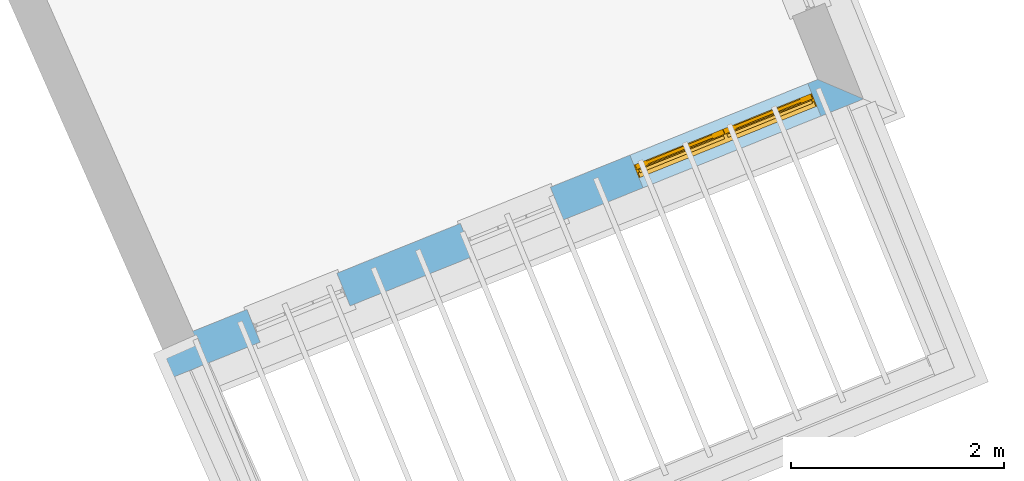
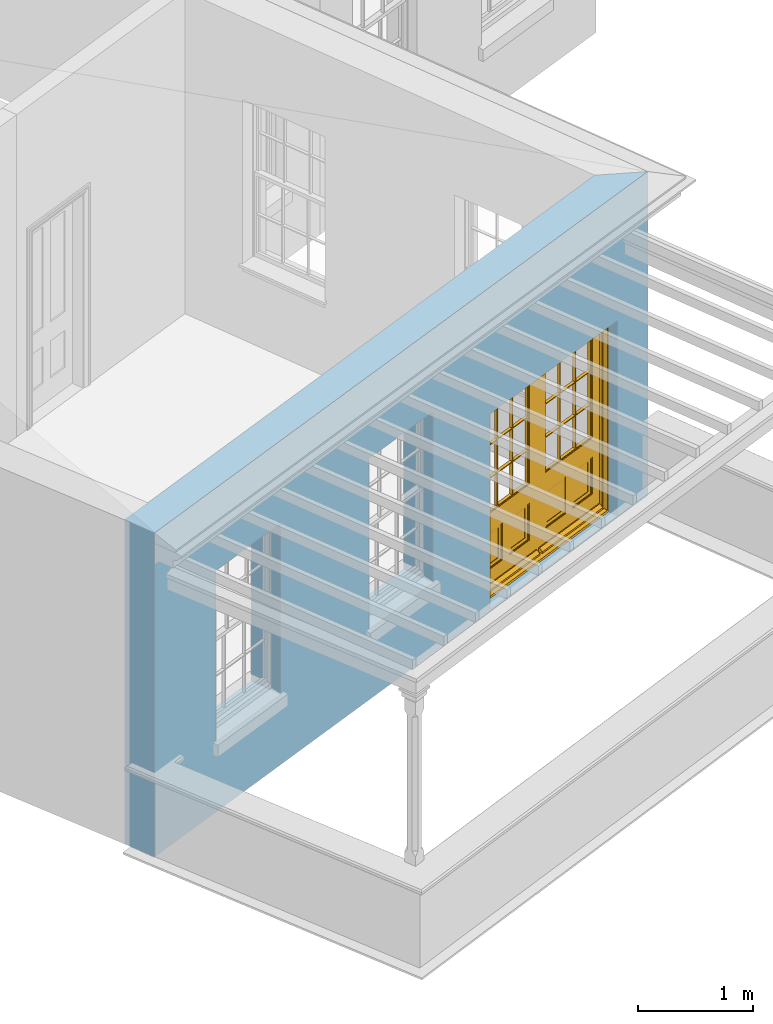
# One storey, part 3 of 11: 1 door, 3 openings, plus 1 element that does not belong to this part.
"""IFC2X3 building model written with IfcOpenShell, lengths in metres."""

import ifcopenshell
import ifcopenshell.guid

model = None  # the IFC model being written
_history = None  # IfcOwnerHistory: only IFC2X3 demands one
_inside = {}  # id of a spatial element -> (the spatial element, [elements in it])
_under = {}  # id of a project, library or spatial element -> (it, [spatial elements below it])
_declared = {}  # id of a project -> (the project, [libraries it declares])
_typed = {}  # id of a type object -> (the type object, [elements of that type])
_made_of = {}  # id of a material, layer set ... -> (it, [elements and type objects made of it])


def new_model(schema):
    """Start an empty IFC model of exactly this schema.

    Asked for "IFC4X3", IfcOpenShell would pick the latest addendum, in which some entities
    have other attributes; the version numbers below select the first issue.
    IFC2X3 requires an IfcOwnerHistory on every rooted entity: one is made here for all.
    """
    global model, _history
    if schema == "IFC4X3":
        model = ifcopenshell.file(schema_version=(4, 3, 0, 0))
    else:
        model = ifcopenshell.file(schema=schema)
    _inside.clear()
    _under.clear()
    _declared.clear()
    _typed.clear()
    _made_of.clear()
    _history = None
    if model.schema == "IFC2X3":
        org = make("IfcOrganization", Name="unknown")
        user = make(
            "IfcPersonAndOrganization",
            ThePerson=make("IfcPerson", FamilyName="unknown"),
            TheOrganization=org,
        )
        app = make(
            "IfcApplication",
            ApplicationDeveloper=org,
            Version="unknown",
            ApplicationFullName="unknown",
            ApplicationIdentifier="unknown",
        )
        _history = make(
            "IfcOwnerHistory",
            OwningUser=user,
            OwningApplication=app,
            ChangeAction="ADDED",
            CreationDate=0,
        )
    return model


def make(cls, **values):
    """One entity of the class cls with the attributes given. An attribute that is None is left unset."""
    return model.create_entity(
        cls, **{name: value for name, value in values.items() if value is not None}
    )


def rooted(cls, **values):
    """An entity with a GlobalId (a new one), such as an element, a storey or a relation."""
    return make(cls, GlobalId=ifcopenshell.guid.new(), OwnerHistory=_history, **values)


def si_unit(unit_type, name, prefix=None):
    """IfcSIUnit, for example si_unit("LENGTHUNIT", "METRE", prefix="MILLI")."""
    return make("IfcSIUnit", UnitType=unit_type, Prefix=prefix, Name=name)


def assignment(units):
    """IfcUnitAssignment: the units of a project."""
    return None if units is None else make("IfcUnitAssignment", Units=units)


def point(xyz):
    """IfcCartesianPoint."""
    return None if xyz is None else make("IfcCartesianPoint", Coordinates=xyz)


def direction(xyz):
    """IfcDirection."""
    return None if xyz is None else make("IfcDirection", DirectionRatios=xyz)


def frame(location, z_axis=None, x_axis=None):
    """IfcAxis2Placement3D, a coordinate frame: its origin and axes. An axis left out is left unset."""
    return make(
        "IfcAxis2Placement3D",
        Location=point(location),
        Axis=direction(z_axis),
        RefDirection=direction(x_axis),
    )


def origin():
    """The frame at (0, 0, 0) with its axes left unset."""
    return frame((0.0, 0.0, 0.0))


def place(relative_to, where):
    """IfcLocalPlacement: puts the frame where relative to a parent placement (None: the world)."""
    return make(
        "IfcLocalPlacement", PlacementRelTo=relative_to, RelativePlacement=where
    )


def context(
    kind, dimensions, precision=None, world=None, true_north=None, identifier=None
):
    """IfcGeometricRepresentationContext, for example the 3D "Model" context."""
    return make(
        "IfcGeometricRepresentationContext",
        ContextIdentifier=identifier,
        ContextType=kind,
        CoordinateSpaceDimension=dimensions,
        Precision=precision,
        WorldCoordinateSystem=world,
        TrueNorth=true_north,
    )


def subcontext(parent, identifier, kind, view, scale=None):
    """IfcGeometricRepresentationSubContext, for example "Body" below "Model"."""
    return make(
        "IfcGeometricRepresentationSubContext",
        ContextIdentifier=identifier,
        ContextType=kind,
        ParentContext=parent,
        TargetScale=scale,
        TargetView=view,
    )


def project(units=None, contexts=None):
    """IfcProject with its units and contexts."""
    return rooted(
        "IfcProject",
        Name="project",
        RepresentationContexts=contexts,
        UnitsInContext=assignment(units),
    )


def spatial(cls, under=None, at=None, **own):
    """A site, building, storey or space (cls), placed at a placement, below another one or the project."""
    s = rooted(cls, ObjectPlacement=at, **own)
    if under is not None:
        _under.setdefault(under.id(), (under, []))[1].append(s)
    return s


def polyline(points):
    """IfcPolyline through the points."""
    return make("IfcPolyline", Points=[point(p) for p in points])


def outline(outer, holes=None, kind="AREA"):
    """IfcArbitraryClosedProfileDef: a profile drawn as a closed curve; with holes, ...WithVoids."""
    if holes is None:
        return make("IfcArbitraryClosedProfileDef", ProfileType=kind, OuterCurve=outer)
    return make(
        "IfcArbitraryProfileDefWithVoids",
        ProfileType=kind,
        OuterCurve=outer,
        InnerCurves=holes,
    )


def extrude(swept, where, along, depth):
    """IfcExtrudedAreaSolid: the profile swept, set in the frame where, extruded along a direction by depth."""
    return make(
        "IfcExtrudedAreaSolid",
        SweptArea=swept,
        Position=where,
        ExtrudedDirection=direction(along),
        Depth=depth,
    )


def faces_of(points, faces, orient=None, outer=None):
    """IfcFace entities. A face is a list of loops; a loop is a list of indices into points, from 0.

    orient and outer hold one flag for each loop. By default every Orientation is true, the
    first loop of a face is its IfcFaceOuterBound and the others are IfcFaceBound.
    """
    made = []
    for i, loops in enumerate(faces):
        bounds = []
        for j, loop in enumerate(loops):
            is_outer = j == 0 if outer is None else outer[i][j]
            bounds.append(
                make(
                    "IfcFaceOuterBound" if is_outer else "IfcFaceBound",
                    Bound=make("IfcPolyLoop", Polygon=[points[k] for k in loop]),
                    Orientation=True if orient is None else orient[i][j],
                )
            )
        made.append(make("IfcFace", Bounds=bounds))
    return made


def faceted_brep(points, faces, orient=None, outer=None, voids=None):
    """IfcFacetedBrep: a solid bounded by flat faces; with voids (closed shells), ...WithVoids."""
    shared = [point(p) for p in points]
    hull = make("IfcClosedShell", CfsFaces=faces_of(shared, faces, orient, outer))
    if voids is None:
        return make("IfcFacetedBrep", Outer=hull)
    return make(
        "IfcFacetedBrepWithVoids",
        Outer=hull,
        Voids=[
            make(cls, CfsFaces=faces_of(shared, fs, o, b)) for cls, fs, o, b in voids
        ],
    )


def shape(context_of_items, identifier, shape_type, items):
    """IfcShapeRepresentation: the items that make up one representation, for example the "Body"."""
    return make(
        "IfcShapeRepresentation",
        ContextOfItems=context_of_items,
        RepresentationIdentifier=identifier,
        RepresentationType=shape_type,
        Items=items,
    )


def material(Name=None, Category=None):
    """IfcMaterial."""
    return make("IfcMaterial", Name=Name, Category=Category)


def layer(
    of_material, thickness, ventilated=None, Name=None, Category=None, Priority=None
):
    """IfcMaterialLayer: one layer of a wall or slab, of a material (None: an air gap)."""
    return make(
        "IfcMaterialLayer",
        Material=of_material,
        LayerThickness=thickness,
        IsVentilated=ventilated,
        Name=Name,
        Category=Category,
        Priority=Priority,
    )


def layer_set(layers, Name=None):
    """IfcMaterialLayerSet."""
    return make("IfcMaterialLayerSet", MaterialLayers=layers, LayerSetName=Name)


def layer_usage(for_layer_set, set_direction, sense, offset, extent=None):
    """IfcMaterialLayerSetUsage: how a layer set lies in its element."""
    return make(
        "IfcMaterialLayerSetUsage",
        ForLayerSet=for_layer_set,
        LayerSetDirection=set_direction,
        DirectionSense=sense,
        OffsetFromReferenceLine=offset,
        ReferenceExtent=extent,
    )


def made_of(thing, what):
    """Note that an element or type object is made of a material, layer set ...; save() writes the relation."""
    if what is not None:
        _made_of.setdefault(what.id(), (what, []))[1].append(thing)
    return thing


def element(
    cls,
    number,
    at=None,
    inside=None,
    cuts=None,
    type_object=None,
    material=None,
    context=None,
    identifier="Body",
    shape_type=None,
    held_by="IfcProductDefinitionShape",
    body=None,
    shapes=None,
    **own,
):
    """One element of the class cls, such as IfcWall. Its Tag is "e" and its number.

    at: its placement. inside: the storey or other place that contains it. cuts: it is an
    opening in that element (IfcRelVoidsElement). A single representation is given by context,
    identifier, shape_type and body (its items); several are given by shapes. held_by: the class
    of the entity that holds the representations. save() writes the other relations.
    """
    e = rooted(cls, Tag="e%d" % number, ObjectPlacement=at, **own)
    if body is not None:
        shapes = [shape(context, identifier, shape_type, body)]
    if shapes is not None:
        e.Representation = make(held_by, Representations=shapes)
    if inside is not None:
        _inside.setdefault(inside.id(), (inside, []))[1].append(e)
    if cuts is not None:
        rooted(
            "IfcRelVoidsElement", RelatingBuildingElement=cuts, RelatedOpeningElement=e
        )
    if type_object is not None:
        _typed.setdefault(type_object.id(), (type_object, []))[1].append(e)
    return made_of(e, material)


def fill(opening, filler):
    """IfcRelFillsElement: the door or window that sits in an opening."""
    return rooted(
        "IfcRelFillsElement",
        RelatingOpeningElement=opening,
        RelatedBuildingElement=filler,
    )


def aggregate(whole, parts):
    """IfcRelAggregates: a whole, such as a stair, and the parts it consists of."""
    return rooted("IfcRelAggregates", RelatingObject=whole, RelatedObjects=parts)


def save(model, path):
    """Write the relations noted so far, then the file.

    IfcRelAggregates (storeys below a building ...), IfcRelContainedInSpatialStructure (elements
    in a storey), IfcRelDefinesByType, IfcRelAssociatesMaterial and IfcRelDeclares: one each for
    every whole, place, type object, material and project.
    """
    for whole, parts in _under.values():
        aggregate(whole, parts)
    for where, things in _inside.values():
        rooted(
            "IfcRelContainedInSpatialStructure",
            RelatedElements=things,
            RelatingStructure=where,
        )
    for kind, things in _typed.values():
        rooted("IfcRelDefinesByType", RelatedObjects=things, RelatingType=kind)
    for what, things in _made_of.values():
        rooted("IfcRelAssociatesMaterial", RelatedObjects=things, RelatingMaterial=what)
    for by, libraries in _declared.values():
        rooted("IfcRelDeclares", RelatingContext=by, RelatedDefinitions=libraries)
    model.write(path)


model = new_model("IFC2X3")

# Units and contexts
model_context = context("Model", 3, world=origin())
body_context = subcontext(model_context, "Body", "Model", "MODEL_VIEW")
ifc_project = project(units=[si_unit("PLANEANGLEUNIT", "RADIAN"), si_unit("MASSUNIT", "GRAM", prefix="KILO"), si_unit("FORCEUNIT", "NEWTON", prefix="KILO"), si_unit("LENGTHUNIT", "METRE")], contexts=[model_context])

# Site, building, storey
site_placement = place(None, origin())
site = spatial("IfcSite", under=ifc_project, at=site_placement, CompositionType="ELEMENT")
building_placement = place(None, origin())
building = spatial("IfcBuilding", under=site, at=building_placement, Name="Building plot-6", CompositionType="ELEMENT")
storey_placement = place(None, frame((0.0, 0.0, 7.6)))
storey = spatial("IfcBuildingStorey", under=building, at=storey_placement, Name="Floor 1", CompositionType="ELEMENT", Elevation=7.6)

# Wall, openings, door
ifc_material = material(Name="Masonry")
ifc_layer = layer(ifc_material, 0.33, ventilated=False)
ifc_layer_set = layer_set([ifc_layer], Name="My Wall")
ifc_layer_usage = layer_usage(ifc_layer_set, "AXIS2", "NEGATIVE", 0.08)
wall_placement = place(storey_placement, origin())
wall = element("IfcWallStandardCase", 1, at=wall_placement, inside=storey, material=ifc_layer_usage, Name="exterior", context=body_context, shape_type="SweptSolid", body=[
    extrude(outline(polyline([(66.9666616124471, 55.8621028205896), (67.0900185225178, 55.5560259140157), (73.5616097026835, 58.1642445482227), (73.1321758860389, 58.3469645447258), (66.9666616124471, 55.8621028205896)])), origin(), (0.0, 0.0, 1.0), 3.45),
])
opening_1_placement = place(storey_placement, frame((0.0, 0.0, 0.75)))
element("IfcOpeningElement", 2, at=opening_1_placement, cuts=wall, Name="Opening", ObjectType="Opening", context=body_context, shape_type="SweptSolid", body=[
    extrude(outline(polyline([(67.9007863622407, 55.8827863240463), (68.7448166197625, 56.2229523487868), (68.6214597096917, 56.5290292553606), (67.77742945217, 56.1888632306201), (67.9007863622407, 55.8827863240463)])), origin(), (0.0, 0.0, 1.0), 1.82),
])
opening_2_placement = place(storey_placement, frame((0.0, 0.0, 0.75)))
element("IfcOpeningElement", 3, at=opening_2_placement, cuts=wall, Name="Opening", ObjectType="Opening", context=body_context, shape_type="SweptSolid", body=[
    extrude(outline(polyline([(69.9033991260465, 56.6898910657159), (70.7474293835683, 57.0300570904565), (70.6240724734975, 57.3361339970303), (69.7800422159758, 56.9959679722898), (69.9033991260465, 56.6898910657159)])), origin(), (0.0, 0.0, 1.0), 1.82),
])
opening_3_placement = place(storey_placement, frame((0.0, 0.0, 0.0199999999999996)))
opening_3 = element("IfcOpeningElement", 4, at=opening_3_placement, cuts=wall, Name="Opening", ObjectType="Opening", context=body_context, shape_type="SweptSolid", body=[
    extrude(outline(polyline([(71.4932718188664, 57.3306508831993), (73.16278221836, 58.0035067563124), (73.0394253082893, 58.3095836628862), (71.3699149087957, 57.6367277897731), (71.4932718188664, 57.3306508831993)])), origin(), (0.0, 0.0, 1.0), 2.08),
])
door_placement = place(storey_placement, frame((71.3998196142674, 57.5625273275734, 0.0199999999999996), z_axis=(0.0, 0.0, 1.0), x_axis=(1.66951039949357, 0.672855873113122, 0.0)))
door = element("IfcDoor", 5, at=door_placement, inside=storey, Name="living outside door", OverallHeight=2.08, OverallWidth=1.8, context=body_context, shape_type="Brep", held_by="IfcProductRepresentation", body=[
    faceted_brep([(0.545, -0.055, 0.265), (0.745, -0.055, 0.265), (0.745, -0.05, 0.265), (0.545, -0.05, 0.265), (0.745, -0.05, 0.58), (0.545, -0.05, 0.58), (0.545, -0.055, 0.58), (0.515, -0.06, 0.235), (0.775, -0.06, 0.235), (0.745, -0.055, 0.58), (0.515, -0.06, 0.61), (0.515, -0.065, 0.235), (0.775, -0.065, 0.235), (0.775, -0.06, 0.61), (0.515, -0.065, 0.61), (0.785, -0.065, 0.225), (0.505, -0.065, 0.225), (0.775, -0.065, 0.61), (0.505, -0.065, 0.62), (0.785, -0.065, 0.62), (0.505, -0.07, 0.225), (0.785, -0.07, 0.225), (0.505, -0.07, 0.62), (0.785, -0.07, 0.62), (0.883, -0.07, 0.075), (0.898, -0.07, 0.075), (0.405, -0.07, 0.62), (0.405, -0.07, 0.225), (0.027, -0.07, 0.075), (0.785, -0.07, 0.82), (0.125, -0.07, 0.82), (0.405, -0.065, 0.62), (0.405, -0.065, 0.225), (0.898, -0.07, 2.068), (0.027, -0.08, 0.075), (0.883, -0.08, 0.075), (0.125, -0.07, 0.225), (0.012, -0.07, 0.075), (0.785, -0.06, 0.82), (0.125, -0.06, 0.82), (0.125, -0.07, 0.62), (0.125, -0.065, 0.62), (0.395, -0.065, 0.61), (0.395, -0.065, 0.235), (0.125, -0.065, 0.225), (0.785, -0.07, 1.895), (0.027, -0.11, 0.045), (0.883, -0.11, 0.045), (0.558333, -0.06, 0.83), (0.351667, -0.06, 0.83), (0.125, -0.07, 1.895), (0.125, -0.06, 1.895), (0.785, -0.06, 1.895), (0.012, -0.07, 2.068), (0.135, -0.065, 0.61), (0.395, -0.06, 0.61), (0.395, -0.06, 0.235), (0.135, -0.065, 0.235), (0.027, -0.11, 0.027), (0.883, -0.11, 0.027), (0.568333, -0.06, 0.83), (0.558333, -0.03, 0.83), (0.351667, -0.03, 0.83), (0.341667, -0.06, 0.83), (0.135, -0.06, 1.185), (0.135, -0.06, 1.53), (0.775, -0.06, 1.53), (0.775, -0.06, 1.185), (0.135, -0.06, 0.61), (0.365, -0.055, 0.58), (0.365, -0.055, 0.265), (0.135, -0.06, 0.235), (0.568333, -0.06, 1.175), (0.558333, -0.06, 1.175), (0.775, -0.06, 0.83), (0.558333, -0.03, 1.175), (0.785, -0.03, 0.82), (0.125, -0.03, 0.82), (0.351667, -0.03, 1.175), (0.351667, -0.06, 1.175), (0.341667, -0.06, 1.175), (0.135, -0.06, 0.83), (0.135, -0.06, 1.175), (0.135, -0.03, 1.185), (0.135, -0.03, 1.53), (0.135, -0.06, 1.54), (0.351667, -0.06, 1.885), (0.558333, -0.06, 1.885), (0.775, -0.03, 1.53), (0.775, -0.03, 1.185), (0.775, -0.06, 1.175), (0.775, -0.06, 1.54), (0.165, -0.055, 0.58), (0.365, -0.05, 0.58), (0.365, -0.05, 0.265), (0.165, -0.055, 0.265), (0.568333, -0.03, 0.83), (0.568333, -0.03, 1.175), (0.568333, -0.06, 1.185), (0.558333, -0.06, 1.185), (0.775, -0.03, 0.83), (0.785, -0.02, 0.82), (0.125, -0.02, 0.82), (0.341667, -0.03, 0.83), (0.341667, -0.03, 1.175), (0.351667, -0.06, 1.185), (0.341667, -0.06, 1.185), (0.135, -0.03, 0.83), (0.341667, -0.03, 1.185), (0.125, -0.03, 1.895), (0.341667, -0.03, 1.53), (0.341667, -0.06, 1.53), (0.135, -0.06, 1.885), (0.341667, -0.06, 1.54), (0.341667, -0.06, 1.885), (0.558333, -0.03, 1.885), (0.351667, -0.03, 1.885), (0.568333, -0.06, 1.885), (0.785, -0.03, 1.895), (0.568333, -0.03, 1.185), (0.568333, -0.06, 1.53), (0.568333, -0.03, 1.53), (0.568333, -0.06, 1.54), (0.775, -0.06, 1.885), (0.165, -0.05, 0.58), (0.165, -0.05, 0.265), (0.775, -0.03, 1.175), (0.558333, -0.06, 1.53), (0.351667, -0.03, 1.185), (0.558333, -0.03, 1.185), (0.505, -0.02, 0.62), (0.405, -0.02, 0.62), (0.125, -0.02, 1.895), (0.785, -0.02, 1.895), (0.351667, -0.06, 1.53), (0.135, -0.03, 1.175), (0.135, -0.03, 1.54), (0.341667, -0.03, 1.54), (0.135, -0.03, 1.885), (0.351667, -0.06, 1.54), (0.558333, -0.03, 1.54), (0.558333, -0.06, 1.54), (0.351667, -0.03, 1.54), (0.775, -0.03, 1.54), (0.568333, -0.03, 1.54), (0.775, -0.03, 1.885), (0.558333, -0.03, 1.53), (0.405, -0.02, 0.225), (0.505, -0.02, 0.225), (0.125, -0.02, 0.62), (0.785, -0.02, 0.62), (0.012, -0.02, 2.068), (0.898, -0.02, 2.068), (0.351667, -0.03, 1.53), (0.341667, -0.03, 1.885), (0.568333, -0.03, 1.885), (0.405, -0.025, 0.225), (0.405, -0.025, 0.62), (0.505, -0.025, 0.62), (0.505, -0.025, 0.225), (0.898, -0.02, 0.027), (0.012, -0.02, 0.027), (0.125, -0.025, 0.62), (0.785, -0.025, 0.62), (0.395, -0.025, 0.235), (0.395, -0.025, 0.61), (0.125, -0.02, 0.225), (0.125, -0.025, 0.225), (0.515, -0.025, 0.61), (0.515, -0.025, 0.235), (0.785, -0.02, 0.225), (0.785, -0.025, 0.225), (0.135, -0.025, 0.61), (0.775, -0.025, 0.61), (0.135, -0.025, 0.235), (0.395, -0.03, 0.235), (0.395, -0.03, 0.61), (0.515, -0.03, 0.61), (0.515, -0.03, 0.235), (0.775, -0.025, 0.235), (0.135, -0.03, 0.61), (0.775, -0.03, 0.61), (0.135, -0.03, 0.235), (0.365, -0.035, 0.265), (0.365, -0.035, 0.58), (0.545, -0.035, 0.58), (0.545, -0.035, 0.265), (0.775, -0.03, 0.235), (0.165, -0.035, 0.58), (0.745, -0.035, 0.58), (0.165, -0.035, 0.265), (0.365, -0.04, 0.58), (0.365, -0.04, 0.265), (0.545, -0.04, 0.58), (0.545, -0.04, 0.265), (0.745, -0.035, 0.265), (0.165, -0.04, 0.58), (0.745, -0.04, 0.58), (0.165, -0.04, 0.265), (0.745, -0.04, 0.265), (1.775, -0.072, 0.025), (0.025, -0.072, 0.025), (0.025, -0.1, 0.025), (1.775, -0.1, 0.025), (1.79, -0.02, 0.025), (0.01, -0.02, 0.025), (1.79, -0.072, 0.025), (1.8, -0.02, 0.0), (0.0, -0.02, 0.0), (0.01, -0.072, 0.025), (1.79, -0.072, 2.07), (1.79, -0.02, 2.07), (1.775, -0.072, 2.055), (1.8, -0.02, 2.08), (0.01, -0.02, 2.07), (0.0, -0.02, 2.08), (0.01, -0.072, 2.07), (0.025, -0.072, 2.055), (0.0, -0.15, 2.08), (1.8, -0.15, 2.08), (0.01, -0.15, 2.07), (1.79, -0.15, 2.07), (0.01, -0.1, 2.07), (1.79, -0.1, 2.07), (0.0, -0.15, 0.0), (1.8, -0.15, 0.0), (0.01, -0.15, 0.025), (1.79, -0.15, 0.025), (0.01, -0.1, 0.025), (0.025, -0.1, 2.055), (1.79, -0.1, 0.025), (1.775, -0.1, 2.055), (0.898, -0.07, 0.027), (0.012, -0.07, 0.027), (0.883, -0.07, 0.027), (0.027, -0.07, 0.027), (1.435, -0.055, 0.265), (1.635, -0.055, 0.265), (1.635, -0.05, 0.265), (1.435, -0.05, 0.265), (1.635, -0.05, 0.58), (1.435, -0.05, 0.58), (1.435, -0.055, 0.58), (1.405, -0.06, 0.235), (1.665, -0.06, 0.235), (1.635, -0.055, 0.58), (1.405, -0.06, 0.61), (1.405, -0.065, 0.235), (1.665, -0.065, 0.235), (1.665, -0.06, 0.61), (1.405, -0.065, 0.61), (1.675, -0.065, 0.225), (1.395, -0.065, 0.225), (1.665, -0.065, 0.61), (1.395, -0.065, 0.62), (1.675, -0.065, 0.62), (1.395, -0.07, 0.225), (1.675, -0.07, 0.225), (1.395, -0.07, 0.62), (1.675, -0.07, 0.62), (1.773, -0.07, 0.075), (1.788, -0.07, 0.075), (1.295, -0.07, 0.62), (1.295, -0.07, 0.225), (0.917, -0.07, 0.075), (1.675, -0.07, 0.82), (1.015, -0.07, 0.82), (1.295, -0.065, 0.62), (1.295, -0.065, 0.225), (1.788, -0.07, 2.068), (0.917, -0.08, 0.075), (1.773, -0.08, 0.075), (1.015, -0.07, 0.225), (0.902, -0.07, 0.075), (1.675, -0.06, 0.82), (1.015, -0.06, 0.82), (1.015, -0.07, 0.62), (1.015, -0.065, 0.62), (1.285, -0.065, 0.61), (1.285, -0.065, 0.235), (1.015, -0.065, 0.225), (1.675, -0.07, 1.895), (0.917, -0.11, 0.045), (1.773, -0.11, 0.045), (1.448333, -0.06, 0.83), (1.241667, -0.06, 0.83), (1.015, -0.07, 1.895), (1.015, -0.06, 1.895), (1.675, -0.06, 1.895), (0.902, -0.07, 2.068), (1.025, -0.065, 0.61), (1.285, -0.06, 0.61), (1.285, -0.06, 0.235), (1.025, -0.065, 0.235), (0.917, -0.11, 0.027), (1.773, -0.11, 0.027), (1.458333, -0.06, 0.83), (1.448333, -0.03, 0.83), (1.241667, -0.03, 0.83), (1.231667, -0.06, 0.83), (1.025, -0.06, 1.185), (1.025, -0.06, 1.53), (1.665, -0.06, 1.53), (1.665, -0.06, 1.185), (1.025, -0.06, 0.61), (1.255, -0.055, 0.58), (1.255, -0.055, 0.265), (1.025, -0.06, 0.235), (1.458333, -0.06, 1.175), (1.448333, -0.06, 1.175), (1.665, -0.06, 0.83), (1.448333, -0.03, 1.175), (1.675, -0.03, 0.82), (1.015, -0.03, 0.82), (1.241667, -0.03, 1.175), (1.241667, -0.06, 1.175), (1.231667, -0.06, 1.175), (1.025, -0.06, 0.83), (1.025, -0.06, 1.175), (1.025, -0.03, 1.185), (1.025, -0.03, 1.53), (1.025, -0.06, 1.54), (1.241667, -0.06, 1.885), (1.448333, -0.06, 1.885), (1.665, -0.03, 1.53), (1.665, -0.03, 1.185), (1.665, -0.06, 1.175), (1.665, -0.06, 1.54), (1.055, -0.055, 0.58), (1.255, -0.05, 0.58), (1.255, -0.05, 0.265), (1.055, -0.055, 0.265), (1.458333, -0.03, 0.83), (1.458333, -0.03, 1.175), (1.458333, -0.06, 1.185), (1.448333, -0.06, 1.185), (1.665, -0.03, 0.83), (1.675, -0.02, 0.82), (1.015, -0.02, 0.82), (1.231667, -0.03, 0.83), (1.231667, -0.03, 1.175), (1.241667, -0.06, 1.185), (1.231667, -0.06, 1.185), (1.025, -0.03, 0.83), (1.231667, -0.03, 1.185), (1.015, -0.03, 1.895), (1.231667, -0.03, 1.53), (1.231667, -0.06, 1.53), (1.025, -0.06, 1.885), (1.231667, -0.06, 1.54), (1.231667, -0.06, 1.885), (1.448333, -0.03, 1.885), (1.241667, -0.03, 1.885), (1.458333, -0.06, 1.885), (1.675, -0.03, 1.895), (1.458333, -0.03, 1.185), (1.458333, -0.06, 1.53), (1.458333, -0.03, 1.53), (1.458333, -0.06, 1.54), (1.665, -0.06, 1.885), (1.055, -0.05, 0.58), (1.055, -0.05, 0.265), (1.665, -0.03, 1.175), (1.448333, -0.06, 1.53), (1.241667, -0.03, 1.185), (1.448333, -0.03, 1.185), (1.395, -0.02, 0.62), (1.295, -0.02, 0.62), (1.015, -0.02, 1.895), (1.675, -0.02, 1.895), (1.241667, -0.06, 1.53), (1.025, -0.03, 1.175), (1.025, -0.03, 1.54), (1.231667, -0.03, 1.54), (1.025, -0.03, 1.885), (1.241667, -0.06, 1.54), (1.448333, -0.03, 1.54), (1.448333, -0.06, 1.54), (1.241667, -0.03, 1.54), (1.665, -0.03, 1.54), (1.458333, -0.03, 1.54), (1.665, -0.03, 1.885), (1.448333, -0.03, 1.53), (1.295, -0.02, 0.225), (1.395, -0.02, 0.225), (1.015, -0.02, 0.62), (1.675, -0.02, 0.62), (0.902, -0.02, 2.068), (1.788, -0.02, 2.068), (1.241667, -0.03, 1.53), (1.231667, -0.03, 1.885), (1.458333, -0.03, 1.885), (1.295, -0.025, 0.225), (1.295, -0.025, 0.62), (1.395, -0.025, 0.62), (1.395, -0.025, 0.225), (1.788, -0.02, 0.027), (0.902, -0.02, 0.027), (1.015, -0.025, 0.62), (1.675, -0.025, 0.62), (1.285, -0.025, 0.235), (1.285, -0.025, 0.61), (1.015, -0.02, 0.225), (1.015, -0.025, 0.225), (1.405, -0.025, 0.61), (1.405, -0.025, 0.235), (1.675, -0.02, 0.225), (1.675, -0.025, 0.225), (1.025, -0.025, 0.61), (1.665, -0.025, 0.61), (1.025, -0.025, 0.235), (1.285, -0.03, 0.235), (1.285, -0.03, 0.61), (1.405, -0.03, 0.61), (1.405, -0.03, 0.235), (1.665, -0.025, 0.235), (1.025, -0.03, 0.61), (1.665, -0.03, 0.61), (1.025, -0.03, 0.235), (1.255, -0.035, 0.265), (1.255, -0.035, 0.58), (1.435, -0.035, 0.58), (1.435, -0.035, 0.265), (1.665, -0.03, 0.235), (1.055, -0.035, 0.58), (1.635, -0.035, 0.58), (1.055, -0.035, 0.265), (1.255, -0.04, 0.58), (1.255, -0.04, 0.265), (1.435, -0.04, 0.58), (1.435, -0.04, 0.265), (1.635, -0.035, 0.265), (1.055, -0.04, 0.58), (1.635, -0.04, 0.58), (1.055, -0.04, 0.265), (1.635, -0.04, 0.265), (1.788, -0.07, 0.027), (0.902, -0.07, 0.027), (1.773, -0.07, 0.027), (0.917, -0.07, 0.027)], [[[0, 1, 2, 3]], [[2, 4, 5, 3]], [[0, 3, 5, 6]], [[1, 0, 7, 8]], [[9, 4, 2, 1]], [[9, 6, 5, 4]], [[0, 6, 10, 7]], [[8, 7, 11, 12]], [[8, 13, 9, 1]], [[13, 10, 6, 9]], [[7, 10, 14, 11]], [[15, 12, 11, 16]], [[12, 17, 13, 8]], [[17, 14, 10, 13]], [[18, 16, 11, 14]], [[15, 19, 17, 12]], [[15, 16, 20, 21]], [[14, 17, 19, 18]], [[16, 18, 22, 20]], [[21, 23, 19, 15]], [[24, 25, 21, 20]], [[23, 22, 18, 19]], [[20, 22, 26, 27]], [[23, 21, 25]], [[28, 24, 20, 27]], [[22, 23, 29]], [[29, 30, 26, 22]], [[27, 26, 31, 32]], [[23, 25, 33, 29]], [[34, 35, 24, 28]], [[28, 27, 36, 37]], [[38, 39, 30, 29]], [[26, 30, 40]], [[26, 40, 41, 31]], [[42, 43, 32, 31]], [[32, 44, 36, 27]], [[33, 45, 29]], [[46, 47, 35, 34]], [[36, 40, 37]], [[39, 38, 48, 49]], [[50, 30, 39, 51]], [[29, 45, 52, 38]], [[53, 37, 40, 30]], [[44, 41, 40, 36]], [[31, 41, 54, 42]], [[43, 42, 55, 56]], [[57, 44, 32, 43]], [[50, 45, 33, 53]], [[47, 46, 58, 59]], [[60, 48, 38]], [[49, 48, 61, 62]], [[49, 63, 39]], [[50, 53, 30]], [[51, 39, 64, 65]], [[45, 50, 51, 52]], [[66, 67, 38, 52]], [[57, 54, 41, 44]], [[42, 54, 68, 55]], [[56, 55, 69, 70]], [[56, 71, 57, 43]], [[60, 72, 73, 48]], [[60, 38, 74]], [[48, 73, 75, 61]], [[76, 77, 62, 61]], [[62, 78, 79, 49]], [[49, 79, 80, 63]], [[63, 81, 39]], [[82, 64, 39]], [[65, 64, 83, 84]], [[85, 51, 65]], [[52, 51, 86, 87]], [[88, 89, 67, 66]], [[90, 38, 67]], [[91, 66, 52]], [[71, 68, 54, 57]], [[55, 68, 92, 69]], [[69, 93, 94, 70]], [[70, 95, 71, 56]], [[96, 97, 72, 60]], [[73, 72, 98, 99]], [[74, 38, 90]], [[100, 96, 60, 74]], [[75, 73, 79, 78]], [[61, 75, 97, 96]], [[101, 102, 77, 76]], [[77, 103, 62]], [[96, 76, 61]], [[103, 104, 78, 62]], [[80, 79, 105, 106]], [[63, 80, 104, 103]], [[81, 63, 103, 107]], [[81, 82, 39]], [[106, 64, 82, 80]], [[106, 108, 83, 64]], [[84, 83, 77, 109]], [[110, 111, 65, 84]], [[112, 51, 85]], [[113, 85, 65, 111]], [[114, 86, 51]], [[115, 87, 86, 116]], [[117, 52, 87]], [[118, 76, 89, 88]], [[119, 98, 67, 89]], [[120, 121, 88, 66]], [[67, 98, 72, 90]], [[91, 122, 120, 66]], [[91, 52, 123]], [[95, 92, 68, 71]], [[69, 92, 124, 93]], [[94, 93, 124, 125]], [[94, 125, 95, 70]], [[72, 97, 126, 90]], [[127, 99, 98, 120]], [[99, 105, 79, 73]], [[74, 90, 126, 100]], [[96, 100, 76]], [[128, 129, 75, 78]], [[97, 75, 129, 119]], [[130, 131, 102, 101]], [[109, 77, 102, 132]], [[133, 101, 76, 118]], [[77, 107, 103]], [[78, 104, 108, 128]], [[111, 106, 105, 134]], [[104, 80, 82, 135]], [[107, 135, 82, 81]], [[110, 108, 106, 111]], [[104, 135, 83, 108]], [[83, 135, 77]], [[136, 84, 109]], [[110, 84, 136, 137]], [[114, 51, 112]], [[85, 136, 138, 112]], [[113, 137, 136, 85]], [[111, 134, 139, 113]], [[86, 114, 113, 139]], [[140, 141, 87, 115]], [[139, 142, 116, 86]], [[109, 118, 115, 116]], [[117, 123, 52]], [[117, 87, 141, 122]], [[126, 89, 76]], [[143, 118, 88]], [[120, 98, 119, 121]], [[119, 89, 126, 97]], [[144, 143, 88, 121]], [[144, 122, 91, 143]], [[127, 120, 122, 141]], [[143, 91, 123, 145]], [[124, 92, 95, 125]], [[146, 129, 99, 127]], [[99, 129, 128, 105]], [[100, 126, 76]], [[121, 119, 129, 146]], [[147, 131, 130, 148]], [[131, 149, 102]], [[130, 101, 150]], [[102, 151, 132]], [[118, 109, 132, 133]], [[101, 133, 152]], [[107, 77, 135]], [[153, 128, 108, 110]], [[134, 105, 128, 153]], [[109, 138, 136]], [[153, 110, 137, 142]], [[154, 114, 112, 138]], [[137, 113, 114, 154]], [[141, 139, 134, 127]], [[141, 140, 142, 139]], [[144, 140, 115, 155]], [[142, 137, 154, 116]], [[155, 115, 118]], [[116, 154, 109]], [[117, 155, 145, 123]], [[122, 144, 155, 117]], [[143, 145, 118]], [[121, 146, 140, 144]], [[146, 127, 134, 153]], [[156, 157, 131, 147]], [[148, 130, 158, 159]], [[148, 160, 161, 147]], [[157, 162, 149, 131]], [[161, 151, 102, 149]], [[101, 152, 160, 150]], [[163, 158, 130, 150]], [[151, 152, 133, 132]], [[154, 138, 109]], [[142, 140, 146, 153]], [[145, 155, 118]], [[157, 156, 164, 165]], [[147, 166, 167, 156]], [[168, 169, 159, 158]], [[170, 148, 159, 171]], [[148, 170, 160]], [[166, 147, 161]], [[172, 162, 157, 165]], [[166, 149, 162, 167]], [[166, 161, 149]], [[150, 160, 170]], [[163, 173, 168, 158]], [[171, 163, 150, 170]], [[174, 164, 156, 167]], [[175, 176, 165, 164]], [[169, 168, 177, 178]], [[171, 159, 169, 179]], [[167, 162, 172, 174]], [[176, 180, 172, 165]], [[179, 173, 163, 171]], [[181, 177, 168, 173]], [[164, 174, 182, 175]], [[183, 184, 176, 175]], [[178, 177, 185, 186]], [[179, 169, 178, 187]], [[174, 172, 180, 182]], [[184, 188, 180, 176]], [[187, 181, 173, 179]], [[189, 185, 177, 181]], [[175, 182, 190, 183]], [[191, 184, 183, 192]], [[185, 193, 194, 186]], [[187, 178, 186, 195]], [[182, 180, 188, 190]], [[191, 196, 188, 184]], [[195, 189, 181, 187]], [[197, 193, 185, 189]], [[183, 190, 198, 192]], [[198, 196, 191, 192]], [[194, 193, 197, 199]], [[195, 186, 194, 199]], [[188, 196, 198, 190]], [[197, 189, 195, 199]], [[200, 201, 202, 203]], [[201, 200, 204, 205]], [[206, 204, 200]], [[204, 207, 208, 205]], [[209, 201, 205]], [[210, 211, 204, 206]], [[206, 200, 212, 210]], [[211, 213, 207, 204]], [[214, 205, 208, 215]], [[216, 217, 201, 209]], [[205, 214, 216, 209]], [[216, 214, 211, 210]], [[210, 212, 217, 216]], [[214, 215, 213, 211]], [[218, 219, 213, 215]], [[219, 218, 220, 221]], [[221, 220, 222, 223]], [[215, 208, 224, 218]], [[225, 224, 208, 207]], [[224, 226, 220, 218]], [[224, 225, 227, 226]], [[219, 225, 207, 213]], [[228, 222, 220, 226]], [[219, 221, 227, 225]], [[226, 227, 203, 202]], [[202, 229, 222, 228]], [[228, 226, 202]], [[227, 221, 223, 230]], [[230, 203, 227]], [[217, 229, 202, 201]], [[231, 223, 222, 229]], [[230, 223, 231, 203]], [[231, 229, 217, 212]], [[212, 200, 203, 231]], [[33, 152, 151, 53]], [[25, 160, 152, 33]], [[161, 37, 53, 151]], [[232, 160, 25]], [[161, 233, 37]], [[160, 232, 234]], [[24, 234, 232, 25]], [[233, 161, 235]], [[37, 233, 235, 28]], [[161, 160, 234, 235]], [[35, 47, 234, 24]], [[28, 235, 46, 34]], [[58, 235, 234, 59]], [[59, 234, 47]], [[58, 46, 235]], [[236, 237, 238, 239]], [[238, 240, 241, 239]], [[236, 239, 241, 242]], [[237, 236, 243, 244]], [[245, 240, 238, 237]], [[245, 242, 241, 240]], [[236, 242, 246, 243]], [[244, 243, 247, 248]], [[244, 249, 245, 237]], [[249, 246, 242, 245]], [[243, 246, 250, 247]], [[251, 248, 247, 252]], [[248, 253, 249, 244]], [[253, 250, 246, 249]], [[254, 252, 247, 250]], [[251, 255, 253, 248]], [[251, 252, 256, 257]], [[250, 253, 255, 254]], [[252, 254, 258, 256]], [[257, 259, 255, 251]], [[260, 261, 257, 256]], [[259, 258, 254, 255]], [[256, 258, 262, 263]], [[259, 257, 261]], [[264, 260, 256, 263]], [[258, 259, 265]], [[265, 266, 262, 258]], [[263, 262, 267, 268]], [[259, 261, 269, 265]], [[270, 271, 260, 264]], [[264, 263, 272, 273]], [[274, 275, 266, 265]], [[262, 266, 276]], [[262, 276, 277, 267]], [[278, 279, 268, 267]], [[268, 280, 272, 263]], [[269, 281, 265]], [[282, 283, 271, 270]], [[272, 276, 273]], [[275, 274, 284, 285]], [[286, 266, 275, 287]], [[265, 281, 288, 274]], [[289, 273, 276, 266]], [[280, 277, 276, 272]], [[267, 277, 290, 278]], [[279, 278, 291, 292]], [[293, 280, 268, 279]], [[286, 281, 269, 289]], [[283, 282, 294, 295]], [[296, 284, 274]], [[285, 284, 297, 298]], [[285, 299, 275]], [[286, 289, 266]], [[287, 275, 300, 301]], [[281, 286, 287, 288]], [[302, 303, 274, 288]], [[293, 290, 277, 280]], [[278, 290, 304, 291]], [[292, 291, 305, 306]], [[292, 307, 293, 279]], [[296, 308, 309, 284]], [[296, 274, 310]], [[284, 309, 311, 297]], [[312, 313, 298, 297]], [[298, 314, 315, 285]], [[285, 315, 316, 299]], [[299, 317, 275]], [[318, 300, 275]], [[301, 300, 319, 320]], [[321, 287, 301]], [[288, 287, 322, 323]], [[324, 325, 303, 302]], [[326, 274, 303]], [[327, 302, 288]], [[307, 304, 290, 293]], [[291, 304, 328, 305]], [[305, 329, 330, 306]], [[306, 331, 307, 292]], [[332, 333, 308, 296]], [[309, 308, 334, 335]], [[310, 274, 326]], [[336, 332, 296, 310]], [[311, 309, 315, 314]], [[297, 311, 333, 332]], [[337, 338, 313, 312]], [[313, 339, 298]], [[332, 312, 297]], [[339, 340, 314, 298]], [[316, 315, 341, 342]], [[299, 316, 340, 339]], [[317, 299, 339, 343]], [[317, 318, 275]], [[342, 300, 318, 316]], [[342, 344, 319, 300]], [[320, 319, 313, 345]], [[346, 347, 301, 320]], [[348, 287, 321]], [[349, 321, 301, 347]], [[350, 322, 287]], [[351, 323, 322, 352]], [[353, 288, 323]], [[354, 312, 325, 324]], [[355, 334, 303, 325]], [[356, 357, 324, 302]], [[303, 334, 308, 326]], [[327, 358, 356, 302]], [[327, 288, 359]], [[331, 328, 304, 307]], [[305, 328, 360, 329]], [[330, 329, 360, 361]], [[330, 361, 331, 306]], [[308, 333, 362, 326]], [[363, 335, 334, 356]], [[335, 341, 315, 309]], [[310, 326, 362, 336]], [[332, 336, 312]], [[364, 365, 311, 314]], [[333, 311, 365, 355]], [[366, 367, 338, 337]], [[345, 313, 338, 368]], [[369, 337, 312, 354]], [[313, 343, 339]], [[314, 340, 344, 364]], [[347, 342, 341, 370]], [[340, 316, 318, 371]], [[343, 371, 318, 317]], [[346, 344, 342, 347]], [[340, 371, 319, 344]], [[319, 371, 313]], [[372, 320, 345]], [[346, 320, 372, 373]], [[350, 287, 348]], [[321, 372, 374, 348]], [[349, 373, 372, 321]], [[347, 370, 375, 349]], [[322, 350, 349, 375]], [[376, 377, 323, 351]], [[375, 378, 352, 322]], [[345, 354, 351, 352]], [[353, 359, 288]], [[353, 323, 377, 358]], [[362, 325, 312]], [[379, 354, 324]], [[356, 334, 355, 357]], [[355, 325, 362, 333]], [[380, 379, 324, 357]], [[380, 358, 327, 379]], [[363, 356, 358, 377]], [[379, 327, 359, 381]], [[360, 328, 331, 361]], [[382, 365, 335, 363]], [[335, 365, 364, 341]], [[336, 362, 312]], [[357, 355, 365, 382]], [[383, 367, 366, 384]], [[367, 385, 338]], [[366, 337, 386]], [[338, 387, 368]], [[354, 345, 368, 369]], [[337, 369, 388]], [[343, 313, 371]], [[389, 364, 344, 346]], [[370, 341, 364, 389]], [[345, 374, 372]], [[389, 346, 373, 378]], [[390, 350, 348, 374]], [[373, 349, 350, 390]], [[377, 375, 370, 363]], [[377, 376, 378, 375]], [[380, 376, 351, 391]], [[378, 373, 390, 352]], [[391, 351, 354]], [[352, 390, 345]], [[353, 391, 381, 359]], [[358, 380, 391, 353]], [[379, 381, 354]], [[357, 382, 376, 380]], [[382, 363, 370, 389]], [[392, 393, 367, 383]], [[384, 366, 394, 395]], [[384, 396, 397, 383]], [[393, 398, 385, 367]], [[397, 387, 338, 385]], [[337, 388, 396, 386]], [[399, 394, 366, 386]], [[387, 388, 369, 368]], [[390, 374, 345]], [[378, 376, 382, 389]], [[381, 391, 354]], [[393, 392, 400, 401]], [[383, 402, 403, 392]], [[404, 405, 395, 394]], [[406, 384, 395, 407]], [[384, 406, 396]], [[402, 383, 397]], [[408, 398, 393, 401]], [[402, 385, 398, 403]], [[402, 397, 385]], [[386, 396, 406]], [[399, 409, 404, 394]], [[407, 399, 386, 406]], [[410, 400, 392, 403]], [[411, 412, 401, 400]], [[405, 404, 413, 414]], [[407, 395, 405, 415]], [[403, 398, 408, 410]], [[412, 416, 408, 401]], [[415, 409, 399, 407]], [[417, 413, 404, 409]], [[400, 410, 418, 411]], [[419, 420, 412, 411]], [[414, 413, 421, 422]], [[415, 405, 414, 423]], [[410, 408, 416, 418]], [[420, 424, 416, 412]], [[423, 417, 409, 415]], [[425, 421, 413, 417]], [[411, 418, 426, 419]], [[427, 420, 419, 428]], [[421, 429, 430, 422]], [[423, 414, 422, 431]], [[418, 416, 424, 426]], [[427, 432, 424, 420]], [[431, 425, 417, 423]], [[433, 429, 421, 425]], [[419, 426, 434, 428]], [[434, 432, 427, 428]], [[430, 429, 433, 435]], [[431, 422, 430, 435]], [[424, 432, 434, 426]], [[433, 425, 431, 435]], [[269, 388, 387, 289]], [[261, 396, 388, 269]], [[397, 273, 289, 387]], [[436, 396, 261]], [[397, 437, 273]], [[396, 436, 438]], [[260, 438, 436, 261]], [[437, 397, 439]], [[273, 437, 439, 264]], [[397, 396, 438, 439]], [[271, 283, 438, 260]], [[264, 439, 282, 270]], [[294, 439, 438, 295]], [[295, 438, 283]], [[294, 282, 439]]]),
])
fill(opening_3, door)

save(model, "model.ifc")
